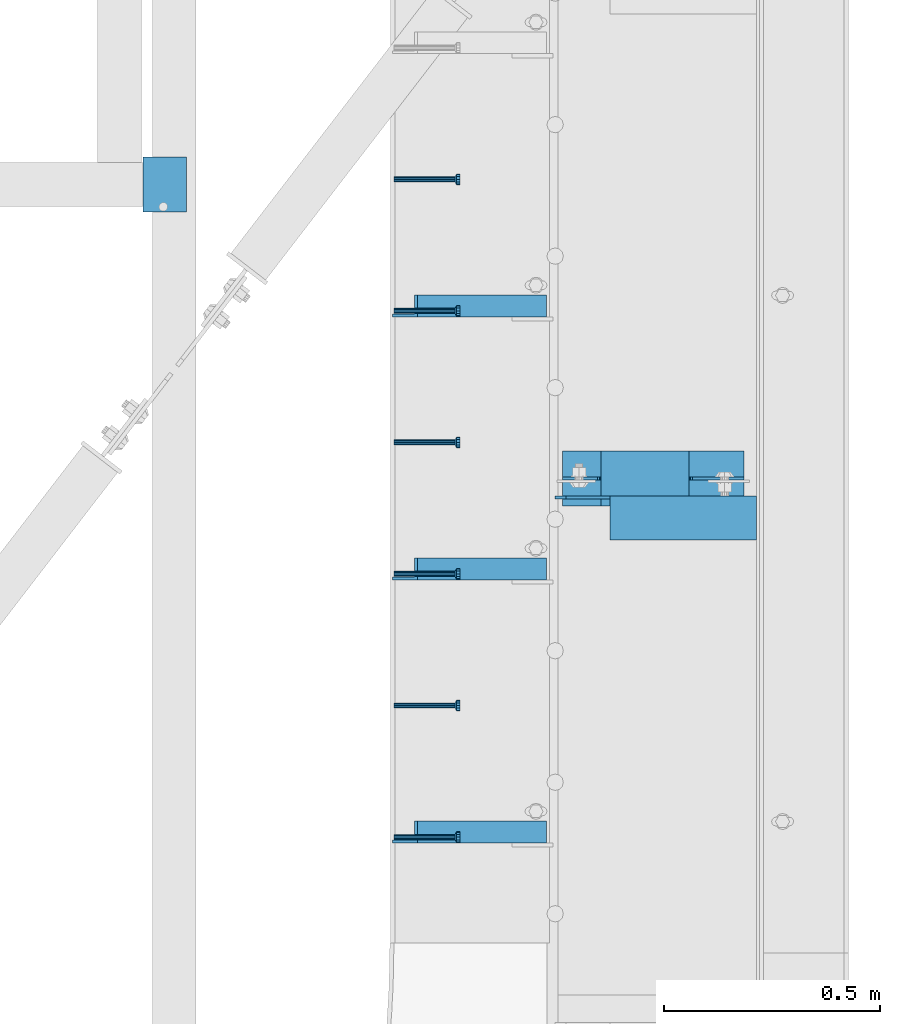
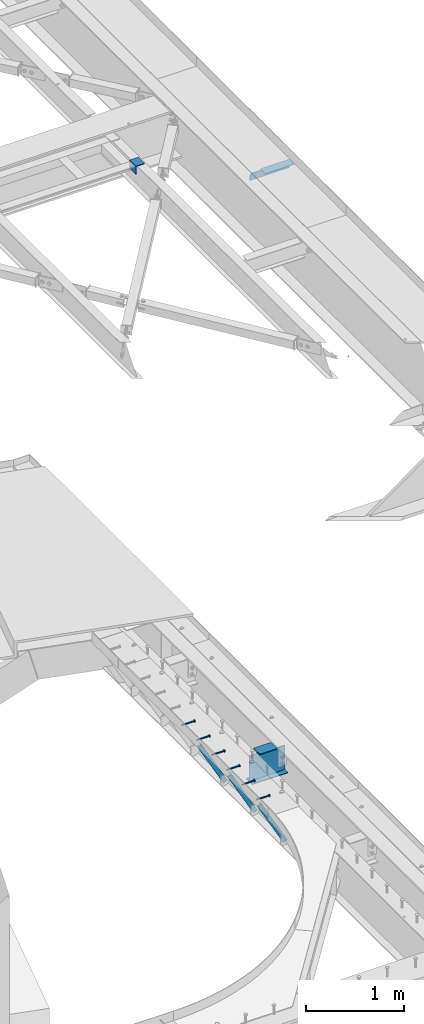
# One storey, part 1380 of 1763: 9 beams, 3 members, 10 elements without a shape of their own.
"""IFC2X3 building model written with IfcOpenShell, lengths in millimetres."""

from ifc_helpers import new_model, si_unit, frame, origin_with_axes, place, context, subcontext, project, spatial, faceted_brep, material, type_object, element, aggregate, save


model = new_model("IFC2X3")

# Units and contexts
model_context = context("Model", 3, precision=1e-05, world=origin_with_axes())
body_context = subcontext(model_context, "Body", "Model", "MODEL_VIEW")
ifc_project = project(units=[si_unit("LENGTHUNIT", "METRE", prefix="MILLI"), si_unit("AREAUNIT", "SQUARE_METRE"), si_unit("VOLUMEUNIT", "CUBIC_METRE"), si_unit("MASSUNIT", "GRAM", prefix="KILO"), si_unit("TIMEUNIT", "SECOND"), si_unit("PLANEANGLEUNIT", "RADIAN"), si_unit("SOLIDANGLEUNIT", "STERADIAN"), si_unit("THERMODYNAMICTEMPERATUREUNIT", "DEGREE_CELSIUS"), si_unit("LUMINOUSINTENSITYUNIT", "LUMEN")], contexts=[model_context])

# Site, building, storey
site_placement = place(None, origin_with_axes())
site = spatial("IfcSite", under=ifc_project, at=site_placement, CompositionType="ELEMENT")
building_placement = place(site_placement, origin_with_axes())
building = spatial("IfcBuilding", under=site, at=building_placement, Name="Undefined", CompositionType="ELEMENT")
storey_placement = place(building_placement, origin_with_axes())
storey = spatial("IfcBuildingStorey", under=building, at=storey_placement, Name="Undefined", CompositionType="ELEMENT", Elevation=0.0)

# Assembly, beam
assembly_1_placement = place(storey_placement, origin_with_axes())
assembly_1 = element("IfcElementAssembly", 1, at=assembly_1_placement, inside=storey, Name="HEADED STUD ANCHOR", AssemblyPlace="NOTDEFINED", PredefinedType="RIGID_FRAME")
ifc_material_1 = material(Name="STEEL/A108")
beam_type_1 = type_object("IfcBeamType", PredefinedType="NOTDEFINED")
beam_1_placement = place(assembly_1_placement, frame((-22037.1277822587, 56938.06875, 5264.15000152588), z_axis=(0.0, 0.0, 1.0), x_axis=(1.0, 0.0, 0.0)))
beam_1 = element("IfcBeam", 2, at=beam_1_placement, type_object=beam_type_1, material=ifc_material_1, Name="HEADED STUD ANCHOR", context=body_context, shape_type="Brep", body=[
    faceted_brep([(0.0, -3.1800000667572, 5.5), (0.0, -5.5, 3.1800000667572), (141.732000000002, -5.5, 3.1800000667572), (141.732000000002, -3.1800000667572, 5.5), (0.0, -6.34999999999491, 1.45519152283669e-11), (141.732000000002, -6.34999990463257, 0.0), (0.0, -5.5, -3.1800000667572), (141.732000000002, -5.5, -3.1800000667572), (0.0, -3.1800000667572, -5.5), (141.732000000002, -3.1800000667572, -5.5), (0.0, 0.0, -6.34999990463257), (141.732000000002, 0.0, -6.34999990463257), (0.0, 3.1800000667572, -5.5), (141.732000000002, 3.1800000667572, -5.5), (0.0, 5.5, -3.1800000667572), (141.732000000002, 5.5, -3.1800000667572), (0.0, 6.34999999999491, -2.91038304567337e-11), (141.732000000002, 6.34999990463257, 0.0), (0.0, 5.5, 3.1800000667572), (141.732000000002, 5.5, 3.1800000667572), (0.0, 3.1800000667572, 5.5), (141.732000000002, 3.1800000667572, 5.5), (0.0, 0.0, 6.34999990463257), (141.732000000002, 0.0, 6.34999990463257), (144.780000000001, -10.9899997711182, 6.34999990463257), (144.780000000001, -6.34000015258789, 10.9899997711182), (144.780000000001, -12.6999998092651, 0.0), (144.780000000001, -10.9899997711182, -6.34999990463257), (144.780000000001, -6.34000015258789, -10.9899997711182), (144.780000000001, 0.0, -12.6899995803833), (144.780000000001, 6.34000015258789, -10.9899997711182), (144.780000000001, 10.9899997711182, -6.34999990463257), (144.780000000001, 12.6999998092651, 0.0), (144.780000000001, 10.9899997711182, 6.34999990463257), (144.780000000001, 6.34000015258789, 10.9899997711182), (144.780000000001, 0.0, 12.6899995803833), (152.400000000001, -10.9899997711182, 6.34999990463257), (152.400000000001, -6.34000015258789, 10.9899997711182), (152.400000000001, -12.6999998092651, 0.0), (152.400000000001, -10.9899997711182, -6.34999990463257), (152.400000000001, -6.34000015258789, -10.9899997711182), (152.400000000001, 0.0, -12.6899995803833), (152.400000000001, 6.34000015258789, -10.9899997711182), (152.400000000001, 10.9899997711182, -6.34999990463257), (152.400000000001, 12.6999998092651, 0.0), (152.400000000001, 10.9899997711182, 6.34999990463257), (152.400000000001, 6.34000015258789, 10.9899997711182), (152.400000000001, 0.0, 12.6899995803833)], [[[0, 1, 2, 3]], [[1, 4, 5, 2]], [[4, 6, 7, 5]], [[6, 8, 9, 7]], [[8, 10, 11, 9]], [[10, 12, 13, 11]], [[12, 14, 15, 13]], [[14, 16, 17, 15]], [[16, 18, 19, 17]], [[18, 20, 21, 19]], [[20, 22, 23, 21]], [[22, 0, 3, 23]], [[22, 20, 18, 16, 14, 12, 10, 8, 6, 4, 1, 0]], [[3, 2, 24, 25]], [[2, 5, 26, 24]], [[5, 7, 27, 26]], [[7, 9, 28, 27]], [[9, 11, 29, 28]], [[11, 13, 30, 29]], [[13, 15, 31, 30]], [[15, 17, 32, 31]], [[17, 19, 33, 32]], [[19, 21, 34, 33]], [[21, 23, 35, 34]], [[23, 3, 25, 35]], [[25, 24, 36, 37]], [[24, 26, 38, 36]], [[26, 27, 39, 38]], [[27, 28, 40, 39]], [[28, 29, 41, 40]], [[29, 30, 42, 41]], [[30, 31, 43, 42]], [[31, 32, 44, 43]], [[32, 33, 45, 44]], [[33, 34, 46, 45]], [[34, 35, 47, 46]], [[35, 25, 37, 47]], [[38, 39, 40, 41, 42, 43, 44, 45, 46, 47, 37, 36]]]),
])
aggregate(assembly_1, [beam_1])

assembly_2_placement = place(storey_placement, origin_with_axes())
assembly_2 = element("IfcElementAssembly", 3, at=assembly_2_placement, inside=storey, Name="HEADED STUD ANCHOR", AssemblyPlace="NOTDEFINED", PredefinedType="RIGID_FRAME")
beam_2_placement = place(assembly_2_placement, frame((-22037.1277822587, 56633.26875, 5264.15000152588), z_axis=(0.0, 0.0, 1.0), x_axis=(1.0, 0.0, 0.0)))
beam_2 = element("IfcBeam", 4, at=beam_2_placement, type_object=beam_type_1, material=ifc_material_1, Name="HEADED STUD ANCHOR", context=body_context, shape_type="Brep", body=[
    faceted_brep([(0.0, -3.1800000667572, 5.5), (0.0, -5.5, 3.1800000667572), (141.732000000002, -5.5, 3.1800000667572), (141.732000000002, -3.1800000667572, 5.5), (0.0, -6.34999999999491, 1.45519152283669e-11), (141.732000000002, -6.34999990463257, 0.0), (0.0, -5.5, -3.1800000667572), (141.732000000002, -5.5, -3.1800000667572), (0.0, -3.1800000667572, -5.5), (141.732000000002, -3.1800000667572, -5.5), (0.0, 0.0, -6.34999990463257), (141.732000000002, 0.0, -6.34999990463257), (0.0, 3.1800000667572, -5.5), (141.732000000002, 3.1800000667572, -5.5), (0.0, 5.5, -3.1800000667572), (141.732000000002, 5.5, -3.1800000667572), (0.0, 6.34999999999491, -2.91038304567337e-11), (141.732000000002, 6.34999990463257, 0.0), (0.0, 5.5, 3.1800000667572), (141.732000000002, 5.5, 3.1800000667572), (0.0, 3.1800000667572, 5.5), (141.732000000002, 3.1800000667572, 5.5), (0.0, 0.0, 6.34999990463257), (141.732000000002, 0.0, 6.34999990463257), (144.780000000001, -10.9899997711182, 6.34999990463257), (144.780000000001, -6.34000015258789, 10.9899997711182), (144.780000000001, -12.6999998092651, 0.0), (144.780000000001, -10.9899997711182, -6.34999990463257), (144.780000000001, -6.34000015258789, -10.9899997711182), (144.780000000001, 0.0, -12.6899995803833), (144.780000000001, 6.34000015258789, -10.9899997711182), (144.780000000001, 10.9899997711182, -6.34999990463257), (144.780000000001, 12.6999998092651, 0.0), (144.780000000001, 10.9899997711182, 6.34999990463257), (144.780000000001, 6.34000015258789, 10.9899997711182), (144.780000000001, 0.0, 12.6899995803833), (152.400000000001, -10.9899997711182, 6.34999990463257), (152.400000000001, -6.34000015258789, 10.9899997711182), (152.400000000001, -12.6999998092651, 0.0), (152.400000000001, -10.9899997711182, -6.34999990463257), (152.400000000001, -6.34000015258789, -10.9899997711182), (152.400000000001, 0.0, -12.6899995803833), (152.400000000001, 6.34000015258789, -10.9899997711182), (152.400000000001, 10.9899997711182, -6.34999990463257), (152.400000000001, 12.6999998092651, 0.0), (152.400000000001, 10.9899997711182, 6.34999990463257), (152.400000000001, 6.34000015258789, 10.9899997711182), (152.400000000001, 0.0, 12.6899995803833)], [[[0, 1, 2, 3]], [[1, 4, 5, 2]], [[4, 6, 7, 5]], [[6, 8, 9, 7]], [[8, 10, 11, 9]], [[10, 12, 13, 11]], [[12, 14, 15, 13]], [[14, 16, 17, 15]], [[16, 18, 19, 17]], [[18, 20, 21, 19]], [[20, 22, 23, 21]], [[22, 0, 3, 23]], [[22, 20, 18, 16, 14, 12, 10, 8, 6, 4, 1, 0]], [[3, 2, 24, 25]], [[2, 5, 26, 24]], [[5, 7, 27, 26]], [[7, 9, 28, 27]], [[9, 11, 29, 28]], [[11, 13, 30, 29]], [[13, 15, 31, 30]], [[15, 17, 32, 31]], [[17, 19, 33, 32]], [[19, 21, 34, 33]], [[21, 23, 35, 34]], [[23, 3, 25, 35]], [[25, 24, 36, 37]], [[24, 26, 38, 36]], [[26, 27, 39, 38]], [[27, 28, 40, 39]], [[28, 29, 41, 40]], [[29, 30, 42, 41]], [[30, 31, 43, 42]], [[31, 32, 44, 43]], [[32, 33, 45, 44]], [[33, 34, 46, 45]], [[34, 35, 47, 46]], [[35, 25, 37, 47]], [[38, 39, 40, 41, 42, 43, 44, 45, 46, 47, 37, 36]]]),
])
aggregate(assembly_2, [beam_2])

assembly_3_placement = place(storey_placement, origin_with_axes())
assembly_3 = element("IfcElementAssembly", 5, at=assembly_3_placement, inside=storey, Name="HEADED STUD ANCHOR", AssemblyPlace="NOTDEFINED", PredefinedType="RIGID_FRAME")
beam_3_placement = place(assembly_3_placement, frame((-22037.1277822587, 56328.46875, 5264.15000152588), z_axis=(0.0, 0.0, 1.0), x_axis=(1.0, 0.0, 0.0)))
beam_3 = element("IfcBeam", 6, at=beam_3_placement, type_object=beam_type_1, material=ifc_material_1, Name="HEADED STUD ANCHOR", context=body_context, shape_type="Brep", body=[
    faceted_brep([(0.0, -3.1800000667572, 5.5), (0.0, -5.5, 3.1800000667572), (141.732000000002, -5.5, 3.1800000667572), (141.732000000002, -3.1800000667572, 5.5), (0.0, -6.34999999999491, 1.45519152283669e-11), (141.732000000002, -6.34999990463257, 0.0), (0.0, -5.5, -3.1800000667572), (141.732000000002, -5.5, -3.1800000667572), (0.0, -3.1800000667572, -5.5), (141.732000000002, -3.1800000667572, -5.5), (0.0, 0.0, -6.34999990463257), (141.732000000002, 0.0, -6.34999990463257), (0.0, 3.1800000667572, -5.5), (141.732000000002, 3.1800000667572, -5.5), (0.0, 5.5, -3.1800000667572), (141.732000000002, 5.5, -3.1800000667572), (0.0, 6.34999999999491, -2.91038304567337e-11), (141.732000000002, 6.34999990463257, 0.0), (0.0, 5.5, 3.1800000667572), (141.732000000002, 5.5, 3.1800000667572), (0.0, 3.1800000667572, 5.5), (141.732000000002, 3.1800000667572, 5.5), (0.0, 0.0, 6.34999990463257), (141.732000000002, 0.0, 6.34999990463257), (144.780000000001, -10.9899997711182, 6.34999990463257), (144.780000000001, -6.34000015258789, 10.9899997711182), (144.780000000001, -12.6999998092651, 0.0), (144.780000000001, -10.9899997711182, -6.34999990463257), (144.780000000001, -6.34000015258789, -10.9899997711182), (144.780000000001, 0.0, -12.6899995803833), (144.780000000001, 6.34000015258789, -10.9899997711182), (144.780000000001, 10.9899997711182, -6.34999990463257), (144.780000000001, 12.6999998092651, 0.0), (144.780000000001, 10.9899997711182, 6.34999990463257), (144.780000000001, 6.34000015258789, 10.9899997711182), (144.780000000001, 0.0, 12.6899995803833), (152.400000000001, -10.9899997711182, 6.34999990463257), (152.400000000001, -6.34000015258789, 10.9899997711182), (152.400000000001, -12.6999998092651, 0.0), (152.400000000001, -10.9899997711182, -6.34999990463257), (152.400000000001, -6.34000015258789, -10.9899997711182), (152.400000000001, 0.0, -12.6899995803833), (152.400000000001, 6.34000015258789, -10.9899997711182), (152.400000000001, 10.9899997711182, -6.34999990463257), (152.400000000001, 12.6999998092651, 0.0), (152.400000000001, 10.9899997711182, 6.34999990463257), (152.400000000001, 6.34000015258789, 10.9899997711182), (152.400000000001, 0.0, 12.6899995803833)], [[[0, 1, 2, 3]], [[1, 4, 5, 2]], [[4, 6, 7, 5]], [[6, 8, 9, 7]], [[8, 10, 11, 9]], [[10, 12, 13, 11]], [[12, 14, 15, 13]], [[14, 16, 17, 15]], [[16, 18, 19, 17]], [[18, 20, 21, 19]], [[20, 22, 23, 21]], [[22, 0, 3, 23]], [[22, 20, 18, 16, 14, 12, 10, 8, 6, 4, 1, 0]], [[3, 2, 24, 25]], [[2, 5, 26, 24]], [[5, 7, 27, 26]], [[7, 9, 28, 27]], [[9, 11, 29, 28]], [[11, 13, 30, 29]], [[13, 15, 31, 30]], [[15, 17, 32, 31]], [[17, 19, 33, 32]], [[19, 21, 34, 33]], [[21, 23, 35, 34]], [[23, 3, 25, 35]], [[25, 24, 36, 37]], [[24, 26, 38, 36]], [[26, 27, 39, 38]], [[27, 28, 40, 39]], [[28, 29, 41, 40]], [[29, 30, 42, 41]], [[30, 31, 43, 42]], [[31, 32, 44, 43]], [[32, 33, 45, 44]], [[33, 34, 46, 45]], [[34, 35, 47, 46]], [[35, 25, 37, 47]], [[38, 39, 40, 41, 42, 43, 44, 45, 46, 47, 37, 36]]]),
])
aggregate(assembly_3, [beam_3])

assembly_4_placement = place(storey_placement, origin_with_axes())
assembly_4 = element("IfcElementAssembly", 7, at=assembly_4_placement, inside=storey, Name="HEADED STUD ANCHOR", AssemblyPlace="NOTDEFINED", PredefinedType="RIGID_FRAME")
beam_4_placement = place(assembly_4_placement, frame((-22037.1277822587, 56023.66875, 5264.15000152588), z_axis=(0.0, 0.0, 1.0), x_axis=(1.0, 0.0, 0.0)))
beam_4 = element("IfcBeam", 8, at=beam_4_placement, type_object=beam_type_1, material=ifc_material_1, Name="HEADED STUD ANCHOR", context=body_context, shape_type="Brep", body=[
    faceted_brep([(0.0, -3.1800000667572, 5.5), (0.0, -5.5, 3.1800000667572), (141.732000000002, -5.5, 3.1800000667572), (141.732000000002, -3.1800000667572, 5.5), (0.0, -6.34999999999491, 1.45519152283669e-11), (141.732000000002, -6.34999990463257, 0.0), (0.0, -5.5, -3.1800000667572), (141.732000000002, -5.5, -3.1800000667572), (0.0, -3.1800000667572, -5.5), (141.732000000002, -3.1800000667572, -5.5), (0.0, 0.0, -6.34999990463257), (141.732000000002, 0.0, -6.34999990463257), (0.0, 3.1800000667572, -5.5), (141.732000000002, 3.1800000667572, -5.5), (0.0, 5.5, -3.1800000667572), (141.732000000002, 5.5, -3.1800000667572), (0.0, 6.34999999999491, -2.91038304567337e-11), (141.732000000002, 6.34999990463257, 0.0), (0.0, 5.5, 3.1800000667572), (141.732000000002, 5.5, 3.1800000667572), (0.0, 3.1800000667572, 5.5), (141.732000000002, 3.1800000667572, 5.5), (0.0, 0.0, 6.34999990463257), (141.732000000002, 0.0, 6.34999990463257), (144.780000000001, -10.9899997711182, 6.34999990463257), (144.780000000001, -6.34000015258789, 10.9899997711182), (144.780000000001, -12.6999998092651, 0.0), (144.780000000001, -10.9899997711182, -6.34999990463257), (144.780000000001, -6.34000015258789, -10.9899997711182), (144.780000000001, 0.0, -12.6899995803833), (144.780000000001, 6.34000015258789, -10.9899997711182), (144.780000000001, 10.9899997711182, -6.34999990463257), (144.780000000001, 12.6999998092651, 0.0), (144.780000000001, 10.9899997711182, 6.34999990463257), (144.780000000001, 6.34000015258789, 10.9899997711182), (144.780000000001, 0.0, 12.6899995803833), (152.400000000001, -10.9899997711182, 6.34999990463257), (152.400000000001, -6.34000015258789, 10.9899997711182), (152.400000000001, -12.6999998092651, 0.0), (152.400000000001, -10.9899997711182, -6.34999990463257), (152.400000000001, -6.34000015258789, -10.9899997711182), (152.400000000001, 0.0, -12.6899995803833), (152.400000000001, 6.34000015258789, -10.9899997711182), (152.400000000001, 10.9899997711182, -6.34999990463257), (152.400000000001, 12.6999998092651, 0.0), (152.400000000001, 10.9899997711182, 6.34999990463257), (152.400000000001, 6.34000015258789, 10.9899997711182), (152.400000000001, 0.0, 12.6899995803833)], [[[0, 1, 2, 3]], [[1, 4, 5, 2]], [[4, 6, 7, 5]], [[6, 8, 9, 7]], [[8, 10, 11, 9]], [[10, 12, 13, 11]], [[12, 14, 15, 13]], [[14, 16, 17, 15]], [[16, 18, 19, 17]], [[18, 20, 21, 19]], [[20, 22, 23, 21]], [[22, 0, 3, 23]], [[22, 20, 18, 16, 14, 12, 10, 8, 6, 4, 1, 0]], [[3, 2, 24, 25]], [[2, 5, 26, 24]], [[5, 7, 27, 26]], [[7, 9, 28, 27]], [[9, 11, 29, 28]], [[11, 13, 30, 29]], [[13, 15, 31, 30]], [[15, 17, 32, 31]], [[17, 19, 33, 32]], [[19, 21, 34, 33]], [[21, 23, 35, 34]], [[23, 3, 25, 35]], [[25, 24, 36, 37]], [[24, 26, 38, 36]], [[26, 27, 39, 38]], [[27, 28, 40, 39]], [[28, 29, 41, 40]], [[29, 30, 42, 41]], [[30, 31, 43, 42]], [[31, 32, 44, 43]], [[32, 33, 45, 44]], [[33, 34, 46, 45]], [[34, 35, 47, 46]], [[35, 25, 37, 47]], [[38, 39, 40, 41, 42, 43, 44, 45, 46, 47, 37, 36]]]),
])
aggregate(assembly_4, [beam_4])

assembly_5_placement = place(storey_placement, origin_with_axes())
assembly_5 = element("IfcElementAssembly", 9, at=assembly_5_placement, inside=storey, Name="HEADED STUD ANCHOR", AssemblyPlace="NOTDEFINED", PredefinedType="RIGID_FRAME")
beam_5_placement = place(assembly_5_placement, frame((-22037.1277822587, 55718.86875, 5264.15000152588), z_axis=(0.0, 0.0, 1.0), x_axis=(1.0, 0.0, 0.0)))
beam_5 = element("IfcBeam", 10, at=beam_5_placement, type_object=beam_type_1, material=ifc_material_1, Name="HEADED STUD ANCHOR", context=body_context, shape_type="Brep", body=[
    faceted_brep([(0.0, -3.1800000667572, 5.5), (0.0, -5.5, 3.1800000667572), (141.732000000002, -5.5, 3.1800000667572), (141.732000000002, -3.1800000667572, 5.5), (0.0, -6.34999999999491, 1.45519152283669e-11), (141.732000000002, -6.34999990463257, 0.0), (0.0, -5.5, -3.1800000667572), (141.732000000002, -5.5, -3.1800000667572), (0.0, -3.1800000667572, -5.5), (141.732000000002, -3.1800000667572, -5.5), (0.0, 0.0, -6.34999990463257), (141.732000000002, 0.0, -6.34999990463257), (0.0, 3.1800000667572, -5.5), (141.732000000002, 3.1800000667572, -5.5), (0.0, 5.5, -3.1800000667572), (141.732000000002, 5.5, -3.1800000667572), (0.0, 6.34999999999491, -2.91038304567337e-11), (141.732000000002, 6.34999990463257, 0.0), (0.0, 5.5, 3.1800000667572), (141.732000000002, 5.5, 3.1800000667572), (0.0, 3.1800000667572, 5.5), (141.732000000002, 3.1800000667572, 5.5), (0.0, 0.0, 6.34999990463257), (141.732000000002, 0.0, 6.34999990463257), (144.780000000001, -10.9899997711182, 6.34999990463257), (144.780000000001, -6.34000015258789, 10.9899997711182), (144.780000000001, -12.6999998092651, 0.0), (144.780000000001, -10.9899997711182, -6.34999990463257), (144.780000000001, -6.34000015258789, -10.9899997711182), (144.780000000001, 0.0, -12.6899995803833), (144.780000000001, 6.34000015258789, -10.9899997711182), (144.780000000001, 10.9899997711182, -6.34999990463257), (144.780000000001, 12.6999998092651, 0.0), (144.780000000001, 10.9899997711182, 6.34999990463257), (144.780000000001, 6.34000015258789, 10.9899997711182), (144.780000000001, 0.0, 12.6899995803833), (152.400000000001, -10.9899997711182, 6.34999990463257), (152.400000000001, -6.34000015258789, 10.9899997711182), (152.400000000001, -12.6999998092651, 0.0), (152.400000000001, -10.9899997711182, -6.34999990463257), (152.400000000001, -6.34000015258789, -10.9899997711182), (152.400000000001, 0.0, -12.6899995803833), (152.400000000001, 6.34000015258789, -10.9899997711182), (152.400000000001, 10.9899997711182, -6.34999990463257), (152.400000000001, 12.6999998092651, 0.0), (152.400000000001, 10.9899997711182, 6.34999990463257), (152.400000000001, 6.34000015258789, 10.9899997711182), (152.400000000001, 0.0, 12.6899995803833)], [[[0, 1, 2, 3]], [[1, 4, 5, 2]], [[4, 6, 7, 5]], [[6, 8, 9, 7]], [[8, 10, 11, 9]], [[10, 12, 13, 11]], [[12, 14, 15, 13]], [[14, 16, 17, 15]], [[16, 18, 19, 17]], [[18, 20, 21, 19]], [[20, 22, 23, 21]], [[22, 0, 3, 23]], [[22, 20, 18, 16, 14, 12, 10, 8, 6, 4, 1, 0]], [[3, 2, 24, 25]], [[2, 5, 26, 24]], [[5, 7, 27, 26]], [[7, 9, 28, 27]], [[9, 11, 29, 28]], [[11, 13, 30, 29]], [[13, 15, 31, 30]], [[15, 17, 32, 31]], [[17, 19, 33, 32]], [[19, 21, 34, 33]], [[21, 23, 35, 34]], [[23, 3, 25, 35]], [[25, 24, 36, 37]], [[24, 26, 38, 36]], [[26, 27, 39, 38]], [[27, 28, 40, 39]], [[28, 29, 41, 40]], [[29, 30, 42, 41]], [[30, 31, 43, 42]], [[31, 32, 44, 43]], [[32, 33, 45, 44]], [[33, 34, 46, 45]], [[34, 35, 47, 46]], [[35, 25, 37, 47]], [[38, 39, 40, 41, 42, 43, 44, 45, 46, 47, 37, 36]]]),
])
aggregate(assembly_5, [beam_5])

assembly_6_placement = place(storey_placement, origin_with_axes())
assembly_6 = element("IfcElementAssembly", 11, at=assembly_6_placement, inside=storey, Name="HEADED STUD ANCHOR", AssemblyPlace="NOTDEFINED", PredefinedType="RIGID_FRAME")
beam_6_placement = place(assembly_6_placement, frame((-22037.1277822587, 55414.06875, 5264.15000152588), z_axis=(0.0, 0.0, 1.0), x_axis=(1.0, 0.0, 0.0)))
beam_6 = element("IfcBeam", 12, at=beam_6_placement, type_object=beam_type_1, material=ifc_material_1, Name="HEADED STUD ANCHOR", context=body_context, shape_type="Brep", body=[
    faceted_brep([(0.0, -3.1800000667572, 5.5), (0.0, -5.5, 3.1800000667572), (141.732000000002, -5.5, 3.1800000667572), (141.732000000002, -3.1800000667572, 5.5), (0.0, -6.34999999999491, 1.45519152283669e-11), (141.732000000002, -6.34999990463257, 0.0), (0.0, -5.5, -3.1800000667572), (141.732000000002, -5.5, -3.1800000667572), (0.0, -3.1800000667572, -5.5), (141.732000000002, -3.1800000667572, -5.5), (0.0, 0.0, -6.34999990463257), (141.732000000002, 0.0, -6.34999990463257), (0.0, 3.1800000667572, -5.5), (141.732000000002, 3.1800000667572, -5.5), (0.0, 5.5, -3.1800000667572), (141.732000000002, 5.5, -3.1800000667572), (0.0, 6.34999999999491, -2.91038304567337e-11), (141.732000000002, 6.34999990463257, 0.0), (0.0, 5.5, 3.1800000667572), (141.732000000002, 5.5, 3.1800000667572), (0.0, 3.1800000667572, 5.5), (141.732000000002, 3.1800000667572, 5.5), (0.0, 0.0, 6.34999990463257), (141.732000000002, 0.0, 6.34999990463257), (144.780000000001, -10.9899997711182, 6.34999990463257), (144.780000000001, -6.34000015258789, 10.9899997711182), (144.780000000001, -12.6999998092651, 0.0), (144.780000000001, -10.9899997711182, -6.34999990463257), (144.780000000001, -6.34000015258789, -10.9899997711182), (144.780000000001, 0.0, -12.6899995803833), (144.780000000001, 6.34000015258789, -10.9899997711182), (144.780000000001, 10.9899997711182, -6.34999990463257), (144.780000000001, 12.6999998092651, 0.0), (144.780000000001, 10.9899997711182, 6.34999990463257), (144.780000000001, 6.34000015258789, 10.9899997711182), (144.780000000001, 0.0, 12.6899995803833), (152.400000000001, -10.9899997711182, 6.34999990463257), (152.400000000001, -6.34000015258789, 10.9899997711182), (152.400000000001, -12.6999998092651, 0.0), (152.400000000001, -10.9899997711182, -6.34999990463257), (152.400000000001, -6.34000015258789, -10.9899997711182), (152.400000000001, 0.0, -12.6899995803833), (152.400000000001, 6.34000015258789, -10.9899997711182), (152.400000000001, 10.9899997711182, -6.34999990463257), (152.400000000001, 12.6999998092651, 0.0), (152.400000000001, 10.9899997711182, 6.34999990463257), (152.400000000001, 6.34000015258789, 10.9899997711182), (152.400000000001, 0.0, 12.6899995803833)], [[[0, 1, 2, 3]], [[1, 4, 5, 2]], [[4, 6, 7, 5]], [[6, 8, 9, 7]], [[8, 10, 11, 9]], [[10, 12, 13, 11]], [[12, 14, 15, 13]], [[14, 16, 17, 15]], [[16, 18, 19, 17]], [[18, 20, 21, 19]], [[20, 22, 23, 21]], [[22, 0, 3, 23]], [[22, 20, 18, 16, 14, 12, 10, 8, 6, 4, 1, 0]], [[3, 2, 24, 25]], [[2, 5, 26, 24]], [[5, 7, 27, 26]], [[7, 9, 28, 27]], [[9, 11, 29, 28]], [[11, 13, 30, 29]], [[13, 15, 31, 30]], [[15, 17, 32, 31]], [[17, 19, 33, 32]], [[19, 21, 34, 33]], [[21, 23, 35, 34]], [[23, 3, 25, 35]], [[25, 24, 36, 37]], [[24, 26, 38, 36]], [[26, 27, 39, 38]], [[27, 28, 40, 39]], [[28, 29, 41, 40]], [[29, 30, 42, 41]], [[30, 31, 43, 42]], [[31, 32, 44, 43]], [[32, 33, 45, 44]], [[33, 34, 46, 45]], [[34, 35, 47, 46]], [[35, 25, 37, 47]], [[38, 39, 40, 41, 42, 43, 44, 45, 46, 47, 37, 36]]]),
])
aggregate(assembly_6, [beam_6])

# Assembly, members
assembly_7_placement = place(storey_placement, origin_with_axes())
assembly_7 = element("IfcElementAssembly", 13, at=assembly_7_placement, inside=storey, Name="BEAM", AssemblyPlace="NOTDEFINED", PredefinedType="RIGID_FRAME")
ifc_material_2 = material(Name="STEEL/A36")
member_type = type_object("IfcMemberType", Name="L2X2X1/4", PredefinedType="NOTDEFINED")
member_1_placement = place(assembly_7_placement, frame((-22018.0026564191, 55425.975, 5206.55507545536), z_axis=(-0.875905243340155, 0.0, -0.482483165187371), x_axis=(0.482483165187372, 0.0, -0.875905243340155)))
member_1 = element("IfcMember", 14, at=member_1_placement, type_object=member_type, material=ifc_material_2, Name="ANGLE", ObjectType="L2X2X1/4", context=body_context, shape_type="Brep", body=[
    faceted_brep([(27.9826493408473, 25.4000000000015, -25.4000000000015), (1.45519152283669e-11, 25.4000000000015, 25.3999999999796), (646.991234315485, 25.4000000000015, 25.4000000007727), (646.991234315505, 25.4000000000015, -25.3999999992993), (1.45519152283669e-11, 19.0499999999993, 25.3999999999796), (646.991234315485, 19.0500000000029, 25.4000000007727), (24.4848192607787, 19.0500000000029, -19.0499999999993), (646.991234315503, 19.0500000000029, -19.0499999992862), (24.4848192607787, -25.4000000000015, -19.0499999999993), (646.991234315503, -25.4000000000015, -19.0499999992862), (27.9826493408473, -25.4000000000015, -25.4000000000015), (646.991234315505, -25.4000000000015, -25.3999999992993)], [[[0, 1, 2, 3]], [[1, 4, 5, 2]], [[4, 6, 7, 5]], [[6, 8, 9, 7]], [[8, 10, 11, 9]], [[10, 0, 3, 11]], [[5, 7, 9, 11, 3, 2]], [[10, 8, 6, 4, 1, 0]]]),
])
member_2_placement = place(assembly_7_placement, frame((-22018.0188163478, 56035.575, 5206.55404526027), z_axis=(-0.875893122315924, 0.0, -0.482505169174034), x_axis=(0.482505169174034, 0.0, -0.875893122315923)))
member_2 = element("IfcMember", 15, at=member_2_placement, type_object=member_type, material=ifc_material_2, Name="ANGLE", ObjectType="L2X2X1/4", context=body_context, shape_type="Brep", body=[
    faceted_brep([(27.9823030647804, 25.4000000000015, -25.3999999999978), (-0.000352314878909965, 25.4000000000015, 25.4000000000124), (646.990957341302, 25.4000000000015, 25.4000000003543), (646.99095734131, 25.4000000000015, -25.399999999674), (-0.000352314878909965, 19.0500000000029, 25.4000000000124), (646.990957341302, 19.0500000000029, 25.4000000003543), (24.4844711423229, 19.0500000000029, -19.0499999999993), (646.99095734131, 19.0500000000029, -19.0499999996682), (24.4844711423229, -25.4000000000015, -19.0499999999993), (646.99095734131, -25.4000000000015, -19.0499999996682), (27.9823030647804, -25.4000000000015, -25.3999999999978), (646.99095734131, -25.4000000000015, -25.399999999674)], [[[0, 1, 2, 3]], [[1, 4, 5, 2]], [[4, 6, 7, 5]], [[6, 8, 9, 7]], [[8, 10, 11, 9]], [[10, 0, 3, 11]], [[5, 7, 9, 11, 3, 2]], [[10, 8, 6, 4, 1, 0]]]),
])
member_3_placement = place(assembly_7_placement, frame((-22018.0026564191, 56645.175, 5206.55507545536), z_axis=(-0.875905243340155, 0.0, -0.482483165187371), x_axis=(0.482483165187372, 0.0, -0.875905243340155)))
member_3 = element("IfcMember", 16, at=member_3_placement, type_object=member_type, material=ifc_material_2, Name="ANGLE", ObjectType="L2X2X1/4", context=body_context, shape_type="Brep", body=[
    faceted_brep([(27.9826493408473, 25.4000000000015, -25.4000000000015), (1.45519152283669e-11, 25.4000000000015, 25.3999999999796), (646.991234315485, 25.4000000000015, 25.4000000007727), (646.991234315505, 25.4000000000015, -25.3999999992993), (1.45519152283669e-11, 19.0499999999993, 25.3999999999796), (646.991234315485, 19.0500000000029, 25.4000000007727), (24.4848192607787, 19.0500000000029, -19.0499999999993), (646.991234315503, 19.0500000000029, -19.0499999992862), (24.4848192607787, -25.4000000000015, -19.0499999999993), (646.991234315503, -25.4000000000015, -19.0499999992862), (27.9826493408473, -25.4000000000015, -25.4000000000015), (646.991234315505, -25.4000000000015, -25.3999999992993)], [[[0, 1, 2, 3]], [[1, 4, 5, 2]], [[4, 6, 7, 5]], [[6, 8, 9, 7]], [[8, 10, 11, 9]], [[10, 0, 3, 11]], [[5, 7, 9, 11, 3, 2]], [[10, 8, 6, 4, 1, 0]]]),
])
aggregate(assembly_7, [member_1, member_2, member_3])

# Assembly, beam
assembly_8_placement = place(storey_placement, origin_with_axes())
assembly_8 = element("IfcElementAssembly", 17, at=assembly_8_placement, inside=storey, Name="BEAM", AssemblyPlace="NOTDEFINED", PredefinedType="RIGID_FRAME")
beam_type_2 = type_object("IfcBeamType", Name="L4X4X1/4", PredefinedType="NOTDEFINED")
beam_7_placement = place(assembly_8_placement, frame((-21196.9646113448, 56153.0499880058, 12395.2), z_axis=(0.0, 0.0, -1.0), x_axis=(-1.0, 0.0, 0.0)))
beam_7 = element("IfcBeam", 18, at=beam_7_placement, type_object=beam_type_2, material=ifc_material_2, Name="BRACE", ObjectType="L4X4X1/4", context=body_context, shape_type="Brep", body=[
    faceted_brep([(1.96450855582952e-10, -50.8000000000338, -44.4499999999534), (2.11002770811319e-10, -50.8000000000357, -50.799999999952), (339.725506103507, -50.8000000000029, -50.7999999999993), (339.725506103507, -50.8000000000029, -44.4500000000007), (-3.63797880709171e-11, 50.8000000000011, -50.8000000000538), (339.725506103507, 50.8000000000029, -50.7999999999993), (339.725506103507, 44.4499999999971, -34.9250007629398), (339.725506103507, 50.8000000000029, -34.9250007629398), (441.325002944937, 50.8000000000029, -34.9250007629398), (441.325002944937, 44.4499999999971, -34.9250007629398), (339.725506103507, 44.4499999999971, -44.4500000000007), (-2.18278728425503e-11, 44.4500000000007, -44.450000000048), (-1.81898940354586e-10, 44.4500000000371, 50.7999999999374), (-1.96450855582952e-10, 50.8000000000393, 50.7999999999374), (466.725006103512, 44.4499999999971, 50.7999999999993), (466.725006103512, 50.8000000000029, 50.7999999999993), (466.725002563468, 50.8000000000029, -9.52499923706091), (466.725002563468, 44.4499999999971, -9.52499923706091)], [[[0, 1, 2, 3]], [[1, 4, 5, 2]], [[6, 7, 8, 9]], [[10, 3, 2, 5, 7, 6]], [[11, 0, 3, 10]], [[1, 0, 11, 12, 13, 4]], [[13, 12, 14, 15]], [[8, 7, 5, 4, 13, 15, 16]], [[9, 8, 16, 17]], [[12, 11, 10, 6, 9, 17, 14]], [[16, 15, 14, 17]]]),
])
aggregate(assembly_8, [beam_7])

assembly_9_placement = place(storey_placement, origin_with_axes())
assembly_9 = element("IfcElementAssembly", 19, at=assembly_9_placement, inside=storey, Name="FRAME", AssemblyPlace="NOTDEFINED", PredefinedType="RIGID_FRAME")
beam_type_3 = type_object("IfcBeamType", Name="L4X4X3/8", PredefinedType="NOTDEFINED")
beam_8_placement = place(assembly_9_placement, frame((-22568.5546174484, 56862.6625, 12404.725), z_axis=(1.0, 0.0, 0.0), x_axis=(0.0, 1.0, 0.0)))
beam_8 = element("IfcBeam", 20, at=beam_8_placement, type_object=beam_type_3, material=ifc_material_2, Name="ANGLE", ObjectType="L4X4X3/8", context=body_context, shape_type="Brep", body=[
    faceted_brep([(-3.63797880709171e-11, 50.8000000000011, -50.8000000000538), (-1.96450855582952e-10, 50.8000000000393, 50.7999999999374), (127.0, 50.7999999999993, 50.7999999999993), (127.0, 50.7999999999993, -50.7999999999993), (0.0, 41.2749999999996, 50.7999999999993), (127.0, 41.2749999999996, 50.7999999999993), (0.0, 41.2749999999996, -41.2750000000015), (127.0, 41.2749999999996, -41.2750000000015), (0.0, -50.7999999999993, -41.2750000000015), (127.0, -50.7999999999993, -41.2750000000015), (2.11002770811319e-10, -50.8000000000357, -50.799999999952), (127.0, -50.7999999999993, -50.7999999999993)], [[[0, 1, 2, 3]], [[1, 4, 5, 2]], [[4, 6, 7, 5]], [[6, 8, 9, 7]], [[8, 10, 11, 9]], [[10, 0, 3, 11]], [[5, 7, 9, 11, 3, 2]], [[10, 8, 6, 4, 1, 0]]]),
])
aggregate(assembly_9, [beam_8])

assembly_10_placement = place(storey_placement, origin_with_axes())
assembly_10 = element("IfcElementAssembly", 21, at=assembly_10_placement, inside=storey, Name="BEAM", AssemblyPlace="NOTDEFINED", PredefinedType="RIGID_FRAME")
ifc_material_3 = material(Name="STEEL/A992")
beam_type_4 = type_object("IfcBeamType", Name="W14X22", PredefinedType="NOTDEFINED")
beam_9_placement = place(assembly_10_placement, frame((-21663.6896174484, 56245.1425415639, 5019.675), z_axis=(0.0, 0.0, 1.0), x_axis=(1.0, 0.0, 0.0)))
beam_9 = element("IfcBeam", 22, at=beam_9_placement, type_object=beam_type_4, material=ifc_material_3, Name="BEAM", ObjectType="W14X22", context=body_context, shape_type="Brep", body=[
    faceted_brep([(310.356250000001, -63.5, 174.625), (310.356250000001, -63.5, 166.6875), (310.356250000001, -3.17500000000291, 166.6875), (310.356250000001, -3.17500000000291, 148.965001487732), (310.356250000001, 3.17500000000291, 148.965001487732), (310.356250000001, 3.17500000000291, 166.6875), (310.356250000001, 63.5, 166.6875), (310.356250000001, 63.5, 174.625), (311.322979922588, -3.17500000000291, 144.104921969686), (311.322979922588, 3.17500000000291, 144.104921969686), (314.075993823066, -3.17500000000291, 139.984745501532), (314.075993823066, 3.17500000000291, 139.984745501532), (318.196170291219, -3.17500000000291, 137.231731601054), (318.196170291219, 3.17500000000291, 137.231731601054), (323.056249809266, -3.17500000000291, 136.265001678466), (323.056249809266, 3.17500000000291, 136.265001678466), (437.356250000001, -3.17500000000291, 136.265001678466), (437.356250000001, 3.17500000000291, 136.265001678466), (106.362500000007, -63.5, 174.625), (106.362500000007, 63.5, 174.625), (106.362500000007, 63.5, 166.6875), (106.362500000007, 3.17500000000291, 166.6875), (106.362500000007, 3.17500000000291, 161.665001487732), (106.362500000007, -3.17500000000291, 161.665001487732), (106.362500000007, -3.17500000000291, 166.6875), (106.362500000007, -63.5, 166.6875), (105.395770077419, 3.17500000000291, 156.804921969687), (105.395770077419, -3.17500000000291, 156.804921969687), (102.642756176941, 3.17500000000291, 152.684745501533), (102.642756176941, -3.17500000000291, 152.684745501533), (98.5225797087878, 3.17500000000291, 149.931731601055), (98.5225797087878, -3.17500000000291, 149.931731601055), (93.6625001907414, 3.17500000000291, 148.965001678467), (93.6625001907414, -3.17500000000291, 148.965001678467), (17.4625000000015, 3.17500000000291, 148.965001678467), (17.4625000000015, -3.17500000000291, 148.965001678467), (17.4625000000015, 3.17500000000291, -166.6875), (17.4625000000015, 63.5, -166.6875), (17.4625000000015, 63.5, -174.625), (17.4625000000015, -63.5, -174.625), (17.4625000000015, -63.5, -166.6875), (17.4625000000015, -3.17500000000291, -166.6875), (437.356250000001, 3.17500000000291, -166.6875), (437.356250000001, 63.5, -166.6875), (437.356250000001, 63.5, -174.625), (437.356250000001, -63.5, -174.625), (437.356250000001, -63.5, -166.6875), (437.356250000001, -3.17500000000291, -166.6875)], [[[0, 1, 2, 3, 4, 5, 6, 7]], [[8, 9, 4, 3]], [[10, 11, 9, 8]], [[12, 13, 11, 10]], [[14, 15, 13, 12]], [[16, 17, 15, 14]], [[18, 19, 20, 21, 22, 23, 24, 25]], [[23, 22, 26, 27]], [[27, 26, 28, 29]], [[29, 28, 30, 31]], [[31, 30, 32, 33]], [[33, 32, 34, 35]], [[36, 37, 38, 39, 40, 41, 35, 34]], [[37, 36, 42, 43]], [[38, 37, 43, 44]], [[39, 38, 44, 45]], [[40, 39, 45, 46]], [[41, 40, 46, 47]], [[12, 10, 8, 3, 2, 24, 23, 27, 29, 31, 33, 35, 41, 47, 16, 14]], [[25, 24, 2, 1]], [[18, 25, 1, 0]], [[19, 18, 0, 7]], [[20, 19, 7, 6]], [[21, 20, 6, 5]], [[42, 36, 34, 32, 30, 28, 26, 22, 21, 5, 4, 9, 11, 13, 15, 17]], [[47, 46, 45, 44, 43, 42, 17, 16]]]),
])
aggregate(assembly_10, [beam_9])

save(model, "model.ifc")
